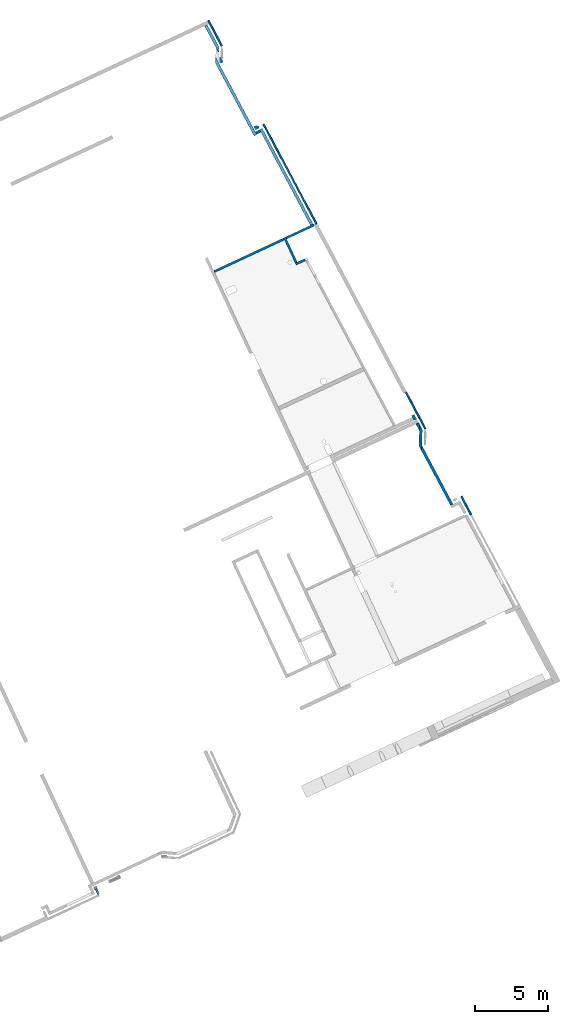
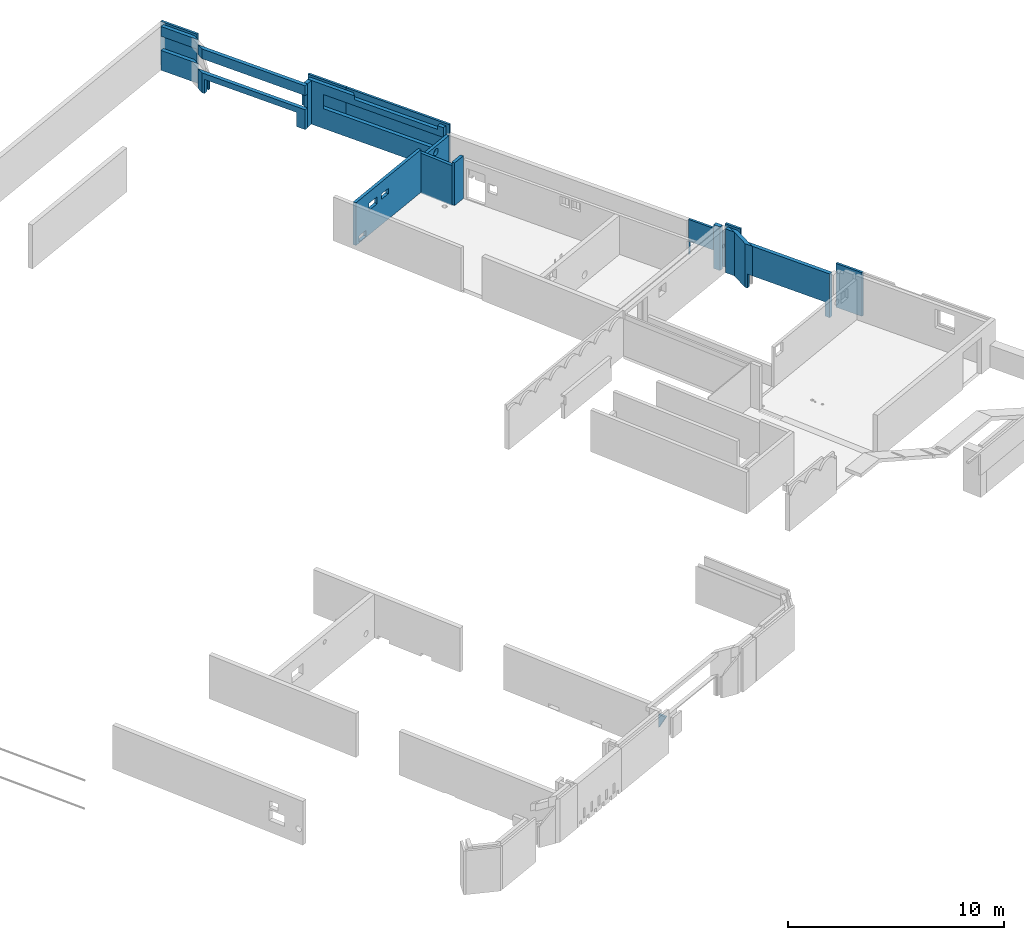
# One storey, part 4 of 13: 21 walls, 16 openings.
"""IFC2X3 building model written with IfcOpenShell, lengths in metres."""

from ifc_helpers import new_model, entity, si_unit, converted_unit, derived_unit, direction, frame, frame_2d, origin, origin_2d_with_axis, place, context, subcontext, project, spatial, polyline, rectangle, circle, outline, extrude, clip, halfspace, bounded_halfspace, material, layer, layer_set, layer_usage, type_object, element, save


model = new_model("IFC2X3")

# Units and contexts
model_context = context("Model", 3, precision=1e-05, world=origin(), true_north=direction((6.12303176911189e-17, 1.0)))
body_context = subcontext(model_context, "Body", "Model", "MODEL_VIEW")
ifc_project = project(units=[si_unit("LENGTHUNIT", "METRE"), si_unit("AREAUNIT", "SQUARE_METRE"), si_unit("VOLUMEUNIT", "CUBIC_METRE"), converted_unit("PLANEANGLEUNIT", "DEGREE", entity("IfcRatioMeasure", 0.0174532925199433), si_unit("PLANEANGLEUNIT", "RADIAN"), dimensions=[0, 0, 0, 0, 0, 0, 0]), si_unit("MASSUNIT", "GRAM", prefix="KILO"), derived_unit("MASSDENSITYUNIT", [(si_unit("MASSUNIT", "GRAM", prefix="KILO"), 1), (si_unit("LENGTHUNIT", "METRE"), -3)]), si_unit("TIMEUNIT", "SECOND"), si_unit("FREQUENCYUNIT", "HERTZ"), si_unit("THERMODYNAMICTEMPERATUREUNIT", "DEGREE_CELSIUS"), derived_unit("THERMALTRANSMITTANCEUNIT", [(si_unit("MASSUNIT", "GRAM", prefix="KILO"), 1), (si_unit("THERMODYNAMICTEMPERATUREUNIT", "KELVIN"), -1), (si_unit("TIMEUNIT", "SECOND"), -3)]), derived_unit("VOLUMETRICFLOWRATEUNIT", [(si_unit("LENGTHUNIT", "METRE"), 3), (si_unit("TIMEUNIT", "SECOND"), -1)]), si_unit("ELECTRICCURRENTUNIT", "AMPERE"), si_unit("ELECTRICVOLTAGEUNIT", "VOLT"), si_unit("POWERUNIT", "WATT"), si_unit("FORCEUNIT", "NEWTON", prefix="KILO"), si_unit("ILLUMINANCEUNIT", "LUX"), si_unit("LUMINOUSFLUXUNIT", "LUMEN"), si_unit("LUMINOUSINTENSITYUNIT", "CANDELA"), derived_unit("USERDEFINED", [(si_unit("MASSUNIT", "GRAM", prefix="KILO"), -1), (si_unit("LENGTHUNIT", "METRE"), -2), (si_unit("TIMEUNIT", "SECOND"), 3), (si_unit("LUMINOUSFLUXUNIT", "LUMEN"), 1)]), derived_unit("LINEARVELOCITYUNIT", [(si_unit("LENGTHUNIT", "METRE"), 1), (si_unit("TIMEUNIT", "SECOND"), -1)]), si_unit("PRESSUREUNIT", "PASCAL"), derived_unit("USERDEFINED", [(si_unit("LENGTHUNIT", "METRE"), -2), (si_unit("MASSUNIT", "GRAM", prefix="KILO"), 1), (si_unit("TIMEUNIT", "SECOND"), -2)])], contexts=[model_context])

# Site, building, storey
site_placement = place(None, frame((5.36960000000003, 43.3158000000006, 0.0), z_axis=(0.0, 0.0, 1.0), x_axis=(-0.422618261740703, 0.906307787036648, 0.0)))
site = spatial("IfcSite", under=ifc_project, at=site_placement, CompositionType="ELEMENT")
building_placement = place(site_placement, origin())
building = spatial("IfcBuilding", under=site, at=building_placement, CompositionType="ELEMENT")
storey_placement = place(building_placement, frame((0.0, 0.0, 2.56)))
storey = spatial("IfcBuildingStorey", under=building, at=storey_placement, CompositionType="ELEMENT", Elevation=2.56)

# Walls
ifc_material_1 = material(Name="C30/37 XC1")
ifc_layer_1 = layer(ifc_material_1, 0.16)
ifc_layer_set_1 = layer_set([ifc_layer_1])
ifc_layer_usage_1 = layer_usage(ifc_layer_set_1, "AXIS2", "NEGATIVE", 0.08)
wall_type_1 = type_object("IfcWallType", PredefinedType="NOTDEFINED", material=ifc_layer_set_1)
wall_1_placement = place(storey_placement, frame((33.4506587545445, 3.50019122287351, 0.0599999999999994), z_axis=(0.0, 0.0, 1.0), x_axis=(0.0, 1.0, 0.0)))
element("IfcWallStandardCase", 1, at=wall_1_placement, inside=storey, type_object=wall_type_1, material=ifc_layer_usage_1, context=body_context, shape_type="Clipping", body=[
    clip(clip(extrude(outline(polyline([(0.874458394319566, -0.079999999999995), (0.874458394319566, 0.0800000000000033), (0.160217183774115, 0.0800000000000007), (0.168567761347161, -0.0799999999999975), (0.714458394319566, -0.0799999999999965), (0.874458394319566, -0.079999999999995)])), origin(), (0.0, 0.0, 1.0), 2.41), bounded_halfspace(frame((0.874458394319565, -0.0799999999999958, 0.0), z_axis=(0.0, 0.0, 1.0), x_axis=(0.0, -1.0, 0.0)), True, frame((0.874458394319565, -0.0799999999999958, 0.0), z_axis=(0.0, 0.0, 1.0), x_axis=(0.0, -1.0, 0.0)), polyline([(0.0, 0.0), (-0.159999999999998, 0.0), (-0.159999999999996, -0.714240629176117), (-0.159999999999981, -0.874458394319565), (0.0, -0.866107809456146), (0.0, -0.160000000000005), (0.0, 0.0)]))), halfspace(frame((0.0, 0.0, -2.62)), True)),
])
ifc_layer_usage_2 = layer_usage(ifc_layer_set_1, "AXIS2", "NEGATIVE", 0.08)
wall_2_placement = place(storey_placement, frame((35.4212010070668, 4.29464961719306, 0.0), z_axis=(0.0, 0.0, 1.0), x_axis=(-1.0, 0.0, 0.0)))
element("IfcWallStandardCase", 2, at=wall_2_placement, inside=storey, type_object=wall_type_1, material=ifc_layer_usage_2, context=body_context, shape_type="Clipping", body=[
    clip(clip(extrude(rectangle(XDim=1.89054225252228, YDim=0.16, at=frame_2d((0.945271126261142, -6.24500451351651e-17), x_axis=(-1.0, 0.0))), origin(), (0.0, 0.0, 1.0), 2.26), bounded_halfspace(frame((0.0, -0.0799999999999997, 2.26), z_axis=(0.0, 0.0, -1.0), x_axis=(0.998640817743402, 0.0521202181191715, 0.0)), True, frame((0.0, -0.0799999999999997, 2.26), z_axis=(0.0, 0.0, -1.0), x_axis=(0.998640817743402, 0.0521202181191715, 0.0)), polyline([(0.0, 0.0), (0.00833923489907021, -0.159782530838944), (1.89631189593637, -0.0612470562739725), (1.88797266103731, 0.0985354745649711), (0.0, 0.0)]))), halfspace(frame((0.0, 0.0, -2.56)), True)),
])

# Wall, opening
ifc_layer_usage_3 = layer_usage(ifc_layer_set_1, "AXIS2", "NEGATIVE", 0.08)
wall_3_placement = place(storey_placement, frame((35.3412010070668, 4.21464961719306, 0.0), z_axis=(0.0, 0.0, 1.0), x_axis=(0.0, -1.0, 0.0)))
wall_3 = element("IfcWallStandardCase", 3, at=wall_3_placement, inside=storey, type_object=wall_type_1, material=ifc_layer_usage_3, context=body_context, shape_type="Clipping", body=[
    clip(clip(extrude(outline(polyline([(2.09788386341345, -0.0799999999999962), (2.09404859778103, -0.00651502726488373), (2.08953327854762, 0.080000000000002), (0.0, 0.0800000000000035), (0.0, -0.0799999999999991), (2.09788386341345, -0.0799999999999962)])), origin(), (0.0, 0.0, 1.0), 1.97), bounded_halfspace(frame((0.0, -0.0800000000000009, 1.97), z_axis=(0.0, 0.0, -1.0), x_axis=(1.0, 0.0, 0.0)), True, frame((0.0, -0.0800000000000009, 1.97), z_axis=(0.0, 0.0, -1.0), x_axis=(1.0, 0.0, 0.0)), polyline([(0.0, 0.0), (0.0, -0.159999999999998), (2.08953327854762, -0.160000000000009), (2.09788386341345, 0.0), (0.0, 0.0)]))), halfspace(frame((0.0, 0.0, -2.56)), True)),
])
opening_1_placement = place(wall_3_placement, origin())
element("IfcOpeningElement", 4, at=opening_1_placement, cuts=wall_3, ObjectType="Opening", context=body_context, shape_type="SweptSolid", body=[
    extrude(circle(Radius=0.18, at=frame_2d((4.19133747219101e-29, -1.08286712929839e-15), x_axis=(1.0, 0.0))), frame((1.03254590087912, -1.604, 1.64499996014938), z_axis=(0.0, 1.0, 0.0), x_axis=(1.0, 0.0, 0.0)), (0.0, 0.0, 1.0), 3.048),
])

# Wall, openings
ifc_layer_usage_4 = layer_usage(ifc_layer_set_1, "AXIS2", "NEGATIVE", 0.08)
wall_4_placement = place(storey_placement, frame((35.3412010070668, 4.37464961719306, 0.0600000000000004), z_axis=(0.0, 0.0, 1.0), x_axis=(0.0, 1.0, 0.0)))
wall_4 = element("IfcWallStandardCase", 5, at=wall_4_placement, inside=storey, type_object=wall_type_1, material=ifc_layer_usage_4, context=body_context, shape_type="Clipping", body=[
    clip(extrude(rectangle(XDim=5.2578762318314, YDim=0.159999999999998, at=frame_2d((2.6289381159157, -5.48172618408671e-16), x_axis=(-1.0, 0.0))), origin(), (0.0, 0.0, 1.0), 2.41), bounded_halfspace(frame((5.2578762318314, -0.0800000000000012, 0.0), z_axis=(0.0, 0.0, 1.0), x_axis=(0.0, -1.0, 0.0)), True, frame((5.2578762318314, -0.0800000000000012, 0.0), z_axis=(0.0, 0.0, 1.0), x_axis=(0.0, -1.0, 0.0)), polyline([(0.0, 0.0), (-0.159999999999998, 0.0), (-0.159999999999999, -5.2578762318314), (0.0, -5.2578762318314), (0.0, 0.0)]))),
])
opening_2_placement = place(wall_4_placement, origin())
element("IfcOpeningElement", 6, at=opening_2_placement, cuts=wall_4, ObjectType="Opening", context=body_context, shape_type="SweptSolid", body=[
    extrude(rectangle(XDim=0.4, YDim=0.649999999999999, at=frame_2d((0.0, 0.0), x_axis=(0.0, 1.0))), frame((3.86472234835323, -1.444, 1.5799999527911), z_axis=(0.0, 1.0, 0.0), x_axis=(-1.0, 0.0, 0.0)), (0.0, 0.0, 1.0), 3.048),
])
opening_3_placement = place(wall_4_placement, origin())
element("IfcOpeningElement", 7, at=opening_3_placement, cuts=wall_4, ObjectType="Opening", context=body_context, shape_type="SweptSolid", body=[
    extrude(rectangle(XDim=0.35, YDim=0.599999999999999, at=frame_2d((-5.55111512312578e-16, 2.77555756156289e-16), x_axis=(0.0, 1.0))), frame((4.72381818330033, -1.444, 0.23), z_axis=(0.0, 1.0, 0.0), x_axis=(-1.0, 0.0, 0.0)), (0.0, 0.0, 1.0), 3.048),
])
opening_4_placement = place(wall_4_placement, origin())
element("IfcOpeningElement", 8, at=opening_4_placement, cuts=wall_4, ObjectType="Opening", context=body_context, shape_type="SweptSolid", body=[
    extrude(rectangle(XDim=0.3, YDim=0.550000000000001, at=frame_2d((0.0, 0.0), x_axis=(0.0, 1.0))), frame((2.92222234835332, -1.444, 1.5799999527911), z_axis=(0.0, 1.0, 0.0), x_axis=(-1.0, 0.0, 0.0)), (0.0, 0.0, 1.0), 3.048),
])

# Wall, opening
ifc_material_2 = material(Name="C30/37 XS1")
ifc_layer_2 = layer(ifc_material_2, 0.2)
ifc_layer_set_2 = layer_set([ifc_layer_2])
ifc_layer_usage_5 = layer_usage(ifc_layer_set_2, "AXIS2", "NEGATIVE", 0.0999999999999944)
wall_type_2 = type_object("IfcWallType", PredefinedType="STANDARD", material=ifc_layer_set_2)
wall_5_placement = place(storey_placement, frame((18.290296023166, 2.068670365154, 0.0), z_axis=(0.0, 0.0, 1.0), x_axis=(0.890908426453977, -0.454182975983576, 0.0)))
wall_5 = element("IfcWallStandardCase", 9, at=wall_5_placement, inside=storey, type_object=wall_type_2, material=ifc_layer_usage_5, context=body_context, shape_type="Clipping", body=[
    clip(extrude(outline(polyline([(1.45975653619654, -0.099999999999993), (1.63193194588306, -0.000594151120496258), (1.80616554859827, 0.0999999999999954), (1.58064928925324, 0.0999999999999951), (0.346410161424922, 0.0999999999999954), (0.0, -0.0999999999999927), (0.399999999923047, -0.0999999999999928), (1.45975653619654, -0.099999999999993)])), origin(), (0.0, 0.0, 1.0), 2.47), halfspace(frame((0.0, 0.0, -2.56)), True)),
])
opening_5_placement = place(wall_5_placement, origin())
element("IfcOpeningElement", 10, at=opening_5_placement, cuts=wall_5, ObjectType="Opening", context=body_context, shape_type="SweptSolid", body=[
    extrude(rectangle(XDim=2.24, YDim=4.22, at=frame_2d((0.0, -1.11022302462516e-15), x_axis=(1.0, 0.0))), frame((-1.49023136623119, -1.19132558835967, -0.32), z_axis=(-0.500000000096165, 0.866025403728918, 0.0), x_axis=(0.0, 0.0, -1.0)), (0.0, 0.0, 1.0), 0.199999999999989),
])

ifc_layer_usage_6 = layer_usage(ifc_layer_set_2, "AXIS2", "NEGATIVE", 0.0999999999999944)
wall_6_placement = place(storey_placement, frame((14.0395793725139, 1.65996403918413, 0.0), z_axis=(0.0, 0.0, 1.0), x_axis=(0.998640817740765, 0.0521202181696847, 0.0)))
wall_6 = element("IfcWallStandardCase", 11, at=wall_6_placement, inside=storey, type_object=wall_type_2, material=ifc_layer_usage_6, context=body_context, shape_type="Clipping", body=[
    clip(extrude(outline(polyline([(4.56265117628364, -0.0999999999999942), (4.21624101485872, 0.0999999999999945), (0.0, 0.0999999999999945), (0.0, -0.0999999999999943), (4.56265117628364, -0.0999999999999942)])), origin(), (0.0, 0.0, 1.0), 2.47), halfspace(frame((0.0, 0.0, -2.56)), True)),
])
opening_6_placement = place(wall_6_placement, origin())
element("IfcOpeningElement", 12, at=opening_6_placement, cuts=wall_6, ObjectType="Opening", context=body_context, shape_type="SweptSolid", body=[
    extrude(rectangle(XDim=2.24, YDim=4.22, at=frame_2d((0.0, -1.11022302462516e-15), x_axis=(1.0, 0.0))), frame((2.37999999998407, -1.42400000000001, -0.32), z_axis=(0.0, 1.0, 0.0), x_axis=(0.0, 0.0, -1.0)), (0.0, 0.0, 1.0), 3.048),
])

ifc_layer_usage_7 = layer_usage(ifc_layer_set_2, "AXIS2", "NEGATIVE", 0.0999999999999944)
wall_7_placement = place(storey_placement, frame((35.4159889852548, 2.24502320895247, 0.0), z_axis=(0.0, 0.0, 1.0), x_axis=(0.998640817743407, 0.0521202181190786, 0.0)))
wall_7 = element("IfcWallStandardCase", 13, at=wall_7_placement, inside=storey, type_object=wall_type_2, material=ifc_layer_usage_7, context=body_context, shape_type="Clipping", body=[
    clip(clip(extrude(outline(polyline([(7.41432183950932, -0.0999999999999944), (7.41432183951121, 0.0999999999999945), (7.21432183951122, 0.0999999999999943), (0.0104382310822942, 0.0999999999999945), (0.0, -0.0999999999999947), (7.41432183950932, -0.0999999999999944)])), origin(), (0.0, 0.0, 1.0), 2.47), bounded_halfspace(frame((0.32871090203765, 0.0999999999999941, 2.26), z_axis=(0.0, 0.0, -1.0), x_axis=(1.0, 0.0, 0.0)), True, frame((0.32871090203765, 0.0999999999999941, 2.26), z_axis=(0.0, 0.0, -1.0), x_axis=(1.0, 0.0, 0.0)), polyline([(0.0, 0.0), (2.46497010441128, 0.0), (4.51973781623594, 0.0), (4.71973781627115, 0.199999999609296), (0.0, 0.199999999999989), (0.0, 0.0)]))), halfspace(frame((0.0, 0.0, -2.56)), True)),
])
opening_7_placement = place(storey_placement, frame((35.4159889852548, 2.24502320895247, 0.0), z_axis=(0.0, 0.0, 1.0), x_axis=(0.998640817743407, 0.0521202181190786, 0.0)))
element("IfcOpeningElement", 14, at=opening_7_placement, cuts=wall_7, ObjectType="Opening", context=body_context, shape_type="SweptSolid", body=[
    extrude(outline(polyline([(-5.28833795567784, -0.149890064186278), (2.12598388383148, -0.149890064186278), (2.12598388383335, 0.0501099358137118), (1.90356747815214, 0.0501099358137114), (1.90356747815214, 0.0496701925593015), (1.25356747815215, 0.0496701925584079), (1.25356747815215, 0.0501099358137114), (-5.27789972459556, 0.0501099358137116), (-5.28833795567784, -0.149890064186278)])), frame((5.28833795567786, 0.049890064186283, 1.12)), (0.0, 0.0, 1.0), 0.8),
])

# Wall, openings
ifc_layer_usage_8 = layer_usage(ifc_layer_set_2, "AXIS2", "NEGATIVE", 0.0999999999999944)
wall_8_placement = place(storey_placement, frame((42.592881530934, 3.15031487012313, 0.0), z_axis=(0.0, 0.0, 1.0), x_axis=(0.998640817743938, 0.052120218108895, 0.0)))
wall_8 = element("IfcWallStandardCase", 15, at=wall_8_placement, inside=storey, type_object=wall_type_2, material=ifc_layer_usage_8, context=body_context, shape_type="Clipping", body=[
    clip(extrude(outline(polyline([(5.97465548690263, -0.0999999999999944), (5.628245325429, 0.0999999999999941), (0.155470865667985, 0.0999999999999944), (0.0, 0.0999999999999941), (0.0, -0.0999999999999947), (0.200000000000151, -0.0999999999999945), (5.5746554869374, -0.0999999999999943), (5.97465548690263, -0.0999999999999944)])), origin(), (0.0, 0.0, 1.0), 2.47), halfspace(frame((0.0, 0.0, -2.56)), True)),
])
opening_8_placement = place(storey_placement, frame((42.592881530934, 3.15031487012313, 0.0), z_axis=(0.0, 0.0, 1.0), x_axis=(0.998640817743938, 0.052120218108895, 0.0)))
element("IfcOpeningElement", 16, at=opening_8_placement, cuts=wall_8, ObjectType="Opening", context=body_context, shape_type="SweptSolid", body=[
    extrude(outline(polyline([(2.29405373313574, -0.0571428571426436), (2.29605373313451, -0.0571428571426436), (2.69605373309973, -0.0571428571426064), (2.34964357162608, 0.142857142857351), (-3.27860175380291, 0.142857142856833), (-3.27860175380275, -0.0571428571431557), (-3.0786012633903, -0.057142857143137), (2.29405373313574, -0.0571428571426436)])), frame((3.27860175380291, -0.0428571428571402, 1.12)), (0.0, 0.0, 1.0), 0.8),
])
opening_9_placement = place(wall_8_placement, origin())
element("IfcOpeningElement", 17, at=opening_9_placement, cuts=wall_8, ObjectType="Opening", context=body_context, shape_type="SweptSolid", body=[
    extrude(rectangle(XDim=2.24, YDim=5.02, at=origin_2d_with_axis()), frame((2.98194861879638, -1.42400000000001, -0.32), z_axis=(0.0, 1.0, 0.0), x_axis=(0.0, 0.0, -1.0)), (0.0, 0.0, 1.0), 3.048),
])

# Walls
ifc_layer_usage_9 = layer_usage(ifc_layer_set_2, "AXIS2", "NEGATIVE", 0.0999999999999944)
wall_9_placement = place(storey_placement, frame((20.3604499800725, 1.4592572333066, 0.0), z_axis=(0.0, 0.0, 1.0), x_axis=(0.998640817747903, 0.0521202180329305, 0.0)))
element("IfcWallStandardCase", 18, at=wall_9_placement, inside=storey, type_object=wall_type_2, material=ifc_layer_usage_9, context=body_context, shape_type="Clipping", body=[
    clip(extrude(outline(polyline([(0.370170593712156, -0.0999999999999943), (0.370170593712158, 0.0999999999999944), (0.010438231064998, 0.0999999999999942), (0.0, -0.0999999999999942), (0.370170593712156, -0.0999999999999943)])), origin(), (0.0, 0.0, 1.0), 2.47), halfspace(frame((0.0, 0.0, -2.56)), True)),
])
ifc_layer_usage_10 = layer_usage(ifc_layer_set_2, "AXIS2", "NEGATIVE", 0.0999999999999944)
wall_10_placement = place(storey_placement, frame((19.5936921088461, 1.41924022793878, 0.0), z_axis=(0.0, 0.0, 1.0), x_axis=(0.998640742880375, 0.0521216525000222, 0.0)))
element("IfcWallStandardCase", 19, at=wall_10_placement, inside=storey, type_object=wall_type_2, material=ifc_layer_usage_10, context=body_context, shape_type="Clipping", body=[
    clip(extrude(outline(polyline([(0.477406646162282, -0.0999999999999944), (0.487845165293734, 0.0999999999999942), (0.0, 0.0999999999999944), (0.151106364807753, 0.0127584102041121), (0.346409012401735, -0.0999999999999944), (0.477406646162282, -0.0999999999999944)])), origin(), (0.0, 0.0, 1.0), 2.47), halfspace(frame((0.0, 0.0, -2.56)), True)),
])

# Wall, opening
ifc_layer_usage_11 = layer_usage(ifc_layer_set_2, "AXIS2", "NEGATIVE", 0.0999999999999944)
wall_11_placement = place(storey_placement, frame((48.758383650042, 2.94137820233539, 0.0), z_axis=(0.0, 0.0, 1.0), x_axis=(0.998640817740654, 0.0521202181718188, 0.0)))
wall_11 = element("IfcWallStandardCase", 20, at=wall_11_placement, inside=storey, type_object=wall_type_2, material=ifc_layer_usage_11, context=body_context, shape_type="Clipping", body=[
    clip(extrude(outline(polyline([(2.04796930345773, -0.0999999999999938), (2.05840753455061, 0.0999999999999951), (0.399999999921568, 0.0999999999999949), (0.0, 0.0999999999999953), (0.346410161423217, -0.0999999999999943), (2.04796930345773, -0.0999999999999938)])), origin(), (0.0, 0.0, 1.0), 2.47), halfspace(frame((0.0, 0.0, -2.56)), True)),
])
opening_10_placement = place(storey_placement, frame((48.758383650042, 2.94137820233539, 0.0), z_axis=(0.0, 0.0, 1.0), x_axis=(0.998640817740654, 0.0521202181718188, 0.0)))
element("IfcOpeningElement", 21, at=opening_10_placement, cuts=wall_11, ObjectType="Opening", context=body_context, shape_type="SweptSolid", body=[
    extrude(outline(polyline([(-0.624147238447406, -0.119999999999994), (1.07741190358711, -0.119999999999994), (1.08785013467997, 0.0799999999999965), (-0.570557399949064, 0.0799999999999952), (-0.970557399870636, 0.0799999999999951), (-0.624147238447406, -0.119999999999994)])), frame((0.970557399870635, 0.0199999999999998, 1.12)), (0.0, 0.0, 1.0), 0.8),
])

ifc_layer_usage_12 = layer_usage(ifc_layer_set_2, "AXIS2", "NEGATIVE", 0.0999999999999944)
wall_12_placement = place(storey_placement, frame((42.7151573064909, 2.72611134039433, 0.0), z_axis=(0.0, 0.0, 1.0), x_axis=(-0.0521202181096505, 0.998640817743899, 0.0)))
wall_12 = element("IfcWallStandardCase", 22, at=wall_12_placement, inside=storey, type_object=wall_type_2, material=ifc_layer_usage_12, context=body_context, shape_type="Clipping", body=[
    clip(extrude(rectangle(XDim=0.329999999909778, YDim=0.199999999999988, at=frame_2d((0.164999999954889, 5.41233724504764e-16), x_axis=(-1.0, 0.0))), origin(), (0.0, 0.0, 1.0), 2.47), halfspace(frame((0.0, 0.0, -2.56)), True)),
])
opening_11_placement = place(wall_12_placement, origin())
element("IfcOpeningElement", 23, at=opening_11_placement, cuts=wall_12, ObjectType="Opening", context=body_context, shape_type="SweptSolid", body=[
    extrude(rectangle(XDim=2.24, YDim=0.12, at=frame_2d((4.92661467177413e-16, -1.11022302462516e-16), x_axis=(0.0, 1.0))), frame((0.120000000063453, -5.38999999999626, -0.319999999999999), z_axis=(0.0, 1.0, 0.0), x_axis=(-1.0, 0.0, 0.0)), (0.0, 0.0, 1.0), 5.01999999999999),
])

ifc_layer_3 = layer(ifc_material_2, 0.12)
ifc_layer_set_3 = layer_set([ifc_layer_3])
ifc_layer_usage_13 = layer_usage(ifc_layer_set_3, "AXIS2", "NEGATIVE", 0.06)
wall_type_3 = type_object("IfcWallType", PredefinedType="STANDARD", material=ifc_layer_set_3)
wall_13_placement = place(storey_placement, frame((0.12066084823765, 34.7675258490254, 0.0)))
wall_13 = element("IfcWallStandardCase", 24, at=wall_13_placement, inside=storey, type_object=wall_type_3, material=ifc_layer_usage_13, context=body_context, shape_type="Clipping", body=[
    clip(clip(extrude(rectangle(XDim=0.409999999999914, YDim=0.119999999999999, at=frame_2d((0.204999999999957, -1.80411241501588e-16), x_axis=(-1.0, 0.0))), origin(), (0.0, 0.0, 1.0), 2.00641558005683), halfspace(frame((0.469999999999914, 0.0, 1.15), z_axis=(-0.880254141226442, 0.0, -0.474502525655764), x_axis=(0.0, -1.0, 0.0)), False)), halfspace(frame((0.0, 0.0, -2.56)), True)),
])
opening_12_placement = place(wall_13_placement, origin())
element("IfcOpeningElement", 25, at=opening_12_placement, cuts=wall_13, ObjectType="Opening", context=body_context, shape_type="SweptSolid", body=[
    extrude(outline(polyline([(-0.382558245815555, -0.0189935114985156), (0.734401035417886, -0.0189935114985103), (-0.351842789602331, 0.0379870229970264), (-0.382558245815555, -0.0189935114985156)])), frame((0.271756028996996, 0.0599999999999994, 1.47773601096235), z_axis=(0.0, -1.0, 0.0), x_axis=(-0.474502525655764, 0.0, 0.880254141226442)), (0.0, 0.0, 1.0), 0.12),
])

# Walls
ifc_layer_usage_14 = layer_usage(ifc_layer_set_3, "AXIS2", "NEGATIVE", 0.06)
wall_14_placement = place(storey_placement, frame((14.3532896147829, 0.835352021015357, 0.0), z_axis=(0.0, 0.0, 1.0), x_axis=(-0.998640817743463, -0.0521202181179958, 0.0)))
element("IfcWallStandardCase", 26, at=wall_14_placement, inside=storey, type_object=wall_type_3, material=ifc_layer_usage_14, context=body_context, shape_type="Clipping", body=[
    clip(extrude(outline(polyline([(1.47650839747395, -0.0600000000000001), (1.48277133612319, 0.0600000000000001), (1.23243107808637, 0.06), (0.0599999999999253, 0.0600000000000001), (0.0599999999999262, -0.0600000000000001), (1.22616813943713, -0.0600000000000001), (1.47650839747395, -0.0600000000000001)])), origin(), (0.0, 0.0, 1.0), 2.47), halfspace(frame((0.0, 0.0, -2.56)), True)),
])
ifc_layer_usage_15 = layer_usage(ifc_layer_set_3, "AXIS2", "NEGATIVE", 0.06)
wall_15_placement = place(storey_placement, frame((43.106024290753, 2.33594173763611, 0.0), z_axis=(0.0, 0.0, 1.0), x_axis=(-0.998640817743471, -0.05212021811784, 0.0)))
element("IfcWallStandardCase", 27, at=wall_15_placement, inside=storey, type_object=wall_type_3, material=ifc_layer_usage_15, context=body_context, shape_type="Clipping", body=[
    clip(extrude(rectangle(XDim=2.08784446242631, YDim=0.12, at=frame_2d((1.10392223121423, 1.59594559789866e-16), x_axis=(-1.0, 0.0))), origin(), (0.0, 0.0, 1.0), 2.47), halfspace(frame((0.0, 0.0, -2.56)), True)),
])

# Wall, openings
ifc_layer_usage_16 = layer_usage(ifc_layer_set_3, "AXIS2", "NEGATIVE", 0.06)
wall_16_placement = place(storey_placement, frame((43.0216087469174, 2.80218705683659, 0.0), z_axis=(0.0, 0.0, 1.0), x_axis=(0.0521202181010397, -0.998640817744348, 0.0)))
wall_16 = element("IfcWallStandardCase", 28, at=wall_16_placement, inside=storey, type_object=wall_type_3, material=ifc_layer_usage_16, context=body_context, shape_type="Clipping", body=[
    clip(clip(extrude(rectangle(XDim=0.410011363393688, YDim=0.120000000000001, at=frame_2d((0.205005681696844, -5.58580959264532e-16), x_axis=(-1.0, 0.0))), origin(), (0.0, 0.0, 1.0), 1.91396143451447), halfspace(frame((0.47001136339267, 0.0, 2.07697571467502), z_axis=(0.923605499404535, 0.0, -0.383344337990924), x_axis=(0.0, -1.0, 0.0)), False)), halfspace(frame((0.0, 0.0, -2.56)), True)),
])
opening_13_placement = place(wall_16_placement, origin())
element("IfcOpeningElement", 29, at=opening_13_placement, cuts=wall_16, ObjectType="Opening", context=body_context, shape_type="SweptSolid", body=[
    extrude(rectangle(XDim=2.24, YDim=0.12, at=frame_2d((4.92661467177413e-16, 0.0), x_axis=(0.0, 1.0))), frame((-0.0600000000000004, 0.0599999999956916, -0.32), z_axis=(0.0, 1.0, 0.0), x_axis=(1.0, 0.0, 0.0)), (0.0, 0.0, 1.0), 5.02),
])
opening_14_placement = place(wall_16_placement, origin())
element("IfcOpeningElement", 30, at=opening_14_placement, cuts=wall_16, ObjectType="Opening", context=body_context, shape_type="SweptSolid", body=[
    extrude(outline(polyline([(-0.914065528566525, -0.0184721500091315), (0.468533119339211, -0.0184721500091319), (0.445532409227312, 0.0369443000182634), (-0.914065528566525, -0.0184721500091315)])), frame((0.136670497798271, 0.0599999999999976, 1.22565857155835), z_axis=(0.0, -1.0, 0.0), x_axis=(-0.383344337990924, 0.0, -0.923605499404535)), (0.0, 0.0, 1.0), 0.12),
])

# Wall, opening
ifc_layer_usage_17 = layer_usage(ifc_layer_set_3, "AXIS2", "NEGATIVE", 0.06)
wall_17_placement = place(storey_placement, frame((48.343543158408, 3.14002662499044, 0.0), z_axis=(0.0, 0.0, 1.0), x_axis=(-0.998640817740777, -0.052120218169461, 0.0)))
wall_17 = element("IfcWallStandardCase", 31, at=wall_17_placement, inside=storey, type_object=wall_type_3, material=ifc_layer_usage_17, context=body_context, shape_type="Clipping", body=[
    clip(extrude(outline(polyline([(5.39230920464406, -0.0599999999999997), (5.39230920465227, 0.0600000000000005), (5.27230920465228, 0.0600000000000002), (0.239999999953936, 0.0600000000000003), (0.0, 0.0600000000000006), (0.207846096855077, -0.0599999999999999), (5.39230920464406, -0.0599999999999997)])), origin(), (0.0, 0.0, 1.0), 0.8), halfspace(frame((0.0, 0.0, -2.56)), True)),
])
opening_15_placement = place(wall_17_placement, origin())
element("IfcOpeningElement", 32, at=opening_15_placement, cuts=wall_17, ObjectType="Opening", context=body_context, shape_type="SweptSolid", body=[
    extrude(rectangle(XDim=2.24, YDim=5.02, at=frame_2d((0.0, 0.0), x_axis=(0.0, 1.0))), frame((2.76230920465246, -1.584, -0.32), z_axis=(0.0, 1.0, 0.0), x_axis=(1.0, 0.0, 0.0)), (0.0, 0.0, 1.0), 3.048),
])

# Walls
ifc_layer_usage_18 = layer_usage(ifc_layer_set_3, "AXIS2", "NEGATIVE", 0.06)
wall_18_placement = place(storey_placement, frame((51.061908624856, 2.75117667902542, 0.0), z_axis=(0.0, 0.0, 1.0), x_axis=(-0.998640817746154, -0.0521202180664373, 0.0)))
element("IfcWallStandardCase", 33, at=wall_18_placement, inside=storey, type_object=wall_type_3, material=ifc_layer_usage_18, context=body_context, shape_type="Clipping", body=[
    clip(extrude(outline(polyline([(1.9916883339487, -0.0599999999999997), (1.9916883339487, 0.0600000000000001), (0.00626293864303214, 0.06), (0.0, -0.0599999999999999), (1.98425734462666, -0.0599999999999998), (1.9916883339487, -0.0599999999999997)])), origin(), (0.0, 0.0, 1.0), 2.47), halfspace(frame((0.0, 0.0, -2.56)), True)),
])
ifc_layer_usage_19 = layer_usage(ifc_layer_set_3, "AXIS2", "NEGATIVE", 0.06)
wall_19_placement = place(storey_placement, frame((40.9610991404087, 2.2239956157712, 0.0), z_axis=(0.0, 0.0, 1.0), x_axis=(-0.998640817743471, -0.05212021811784, 0.0)))
element("IfcWallStandardCase", 34, at=wall_19_placement, inside=storey, type_object=wall_type_3, material=ifc_layer_usage_19, context=body_context, shape_type="Clipping", body=[
    clip(extrude(rectangle(XDim=0.12, YDim=5.6241547885853, at=frame_2d((2.81207739429257, 3.33066907387547e-16), x_axis=(0.0, 1.0))), origin(), (0.0, 0.0, 1.0), 2.47), halfspace(frame((0.0, 0.0, -2.56)), True)),
])

# Wall, opening
ifc_layer_usage_20 = layer_usage(ifc_layer_set_3, "AXIS2", "NEGATIVE", 0.06)
wall_20_placement = place(storey_placement, frame((22.3246681172604, 1.25133455913433, 0.0), z_axis=(0.0, 0.0, 1.0), x_axis=(-0.998640817743471, -0.05212021811784, 0.0)))
wall_20 = element("IfcWallStandardCase", 35, at=wall_20_placement, inside=storey, type_object=wall_type_3, material=ifc_layer_usage_20, context=body_context, shape_type="Clipping", body=[
    clip(clip(clip(extrude(rectangle(XDim=1.96198456261743, YDim=0.12, at=frame_2d((0.980992281308716, 1.07552855510562e-16), x_axis=(-1.0, 0.0))), origin(), (0.0, 0.0, 1.0), 2.31), bounded_halfspace(frame((1.95854091635976, -0.0599999999999998, 1.97), z_axis=(0.0, 0.0, -1.0), x_axis=(0.0521202181178492, 0.998640817743471, 0.0)), True, frame((1.95854091635976, -0.0599999999999998, 1.97), z_axis=(0.0, 0.0, -1.0), x_axis=(0.0521202181178492, 0.998640817743471, 0.0)), polyline([(0.0, 0.0), (-0.102079579753403, -1.95587890229755), (0.0177573183758139, -1.96213332847169), (0.120016381723287, -0.00281546045935774), (0.066071217313226, 0.0), (0.0, 0.0)]))), bounded_halfspace(frame((1.96198456261743, 0.00598141448698687, 1.97), z_axis=(0.998640817743471, -0.05212021811785, 0.0), x_axis=(0.0, 0.0, 1.0)), True, frame((1.96198456261743, 0.00598141448698687, 1.97), z_axis=(0.998640817743471, -0.05212021811785, 0.0), x_axis=(0.0, 0.0, 1.0)), polyline([(0.0, 0.0), (0.34, 0.0), (0.34, 0.0660712173132259), (0.0, 0.066071217313226), (0.0, 0.0)]))), halfspace(frame((0.0, 0.0, -2.56)), True)),
])
opening_16_placement = place(wall_20_placement, origin())
element("IfcOpeningElement", 36, at=opening_16_placement, cuts=wall_20, ObjectType="Opening", context=body_context, shape_type="SweptSolid", body=[
    extrude(rectangle(XDim=3.8, YDim=1.52, at=frame_2d((2.16493489801906e-15, 0.0), x_axis=(0.0, 1.0))), frame((0.803328780570053, -1.584, -1.16), z_axis=(0.0, 1.0, 0.0), x_axis=(1.0, 0.0, 0.0)), (0.0, 0.0, 1.0), 3.048),
])

# Wall
ifc_layer_usage_21 = layer_usage(ifc_layer_set_3, "AXIS2", "NEGATIVE", 0.06)
wall_21_placement = place(storey_placement, frame((20.325811157366, 1.14706481872836, 0.0), z_axis=(0.0, 0.0, 1.0), x_axis=(-0.998640742880375, -0.0521216525000237, 0.0)))
element("IfcWallStandardCase", 37, at=wall_21_placement, inside=storey, type_object=wall_type_3, material=ifc_layer_usage_21, context=body_context, shape_type="Clipping", body=[
    clip(extrude(rectangle(XDim=0.827560171608591, YDim=0.12, at=frame_2d((0.413780085804295, 2.77555756156289e-17), x_axis=(-1.0, 0.0))), origin(), (0.0, 0.0, 1.0), 2.47), halfspace(frame((0.0, 0.0, -2.56)), True)),
])

save(model, "model.ifc")
